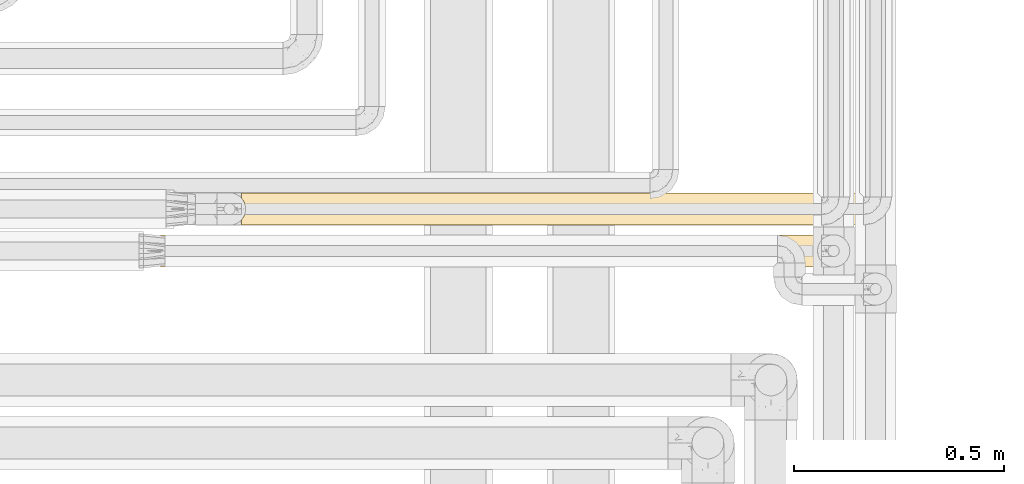
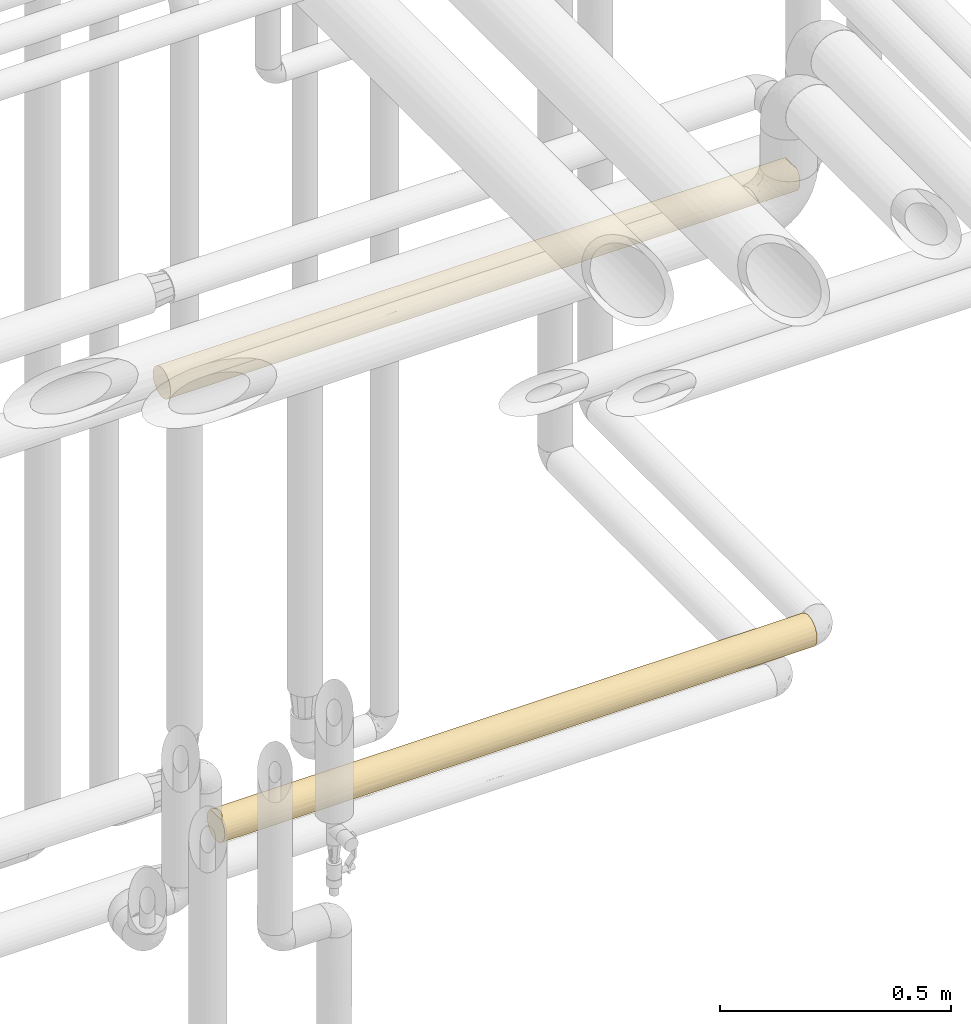
# One storey, part 49 of 827: 2 coverings.
"""IFC2X3 building model written with IfcOpenShell, lengths in millimetres."""

from ifc_helpers import new_model, entity, si_unit, converted_unit, derived_unit, direction, frame, origin, place, context, subcontext, project, spatial, faceted_brep, element, save


model = new_model("IFC2X3")

# Units and contexts
model_context = context("Model", 3, precision=0.01, world=origin(), true_north=direction((6.12303176911189e-17, 1.0)))
body_context = subcontext(model_context, "Body", "Model", "MODEL_VIEW")
ifc_project = project(units=[si_unit("LENGTHUNIT", "METRE", prefix="MILLI"), si_unit("AREAUNIT", "SQUARE_METRE"), si_unit("VOLUMEUNIT", "CUBIC_METRE"), converted_unit("PLANEANGLEUNIT", "DEGREE", entity("IfcRatioMeasure", 0.0174532925199433), si_unit("PLANEANGLEUNIT", "RADIAN"), dimensions=[0, 0, 0, 0, 0, 0, 0]), si_unit("MASSUNIT", "GRAM", prefix="KILO"), derived_unit("MASSDENSITYUNIT", [(si_unit("MASSUNIT", "GRAM", prefix="KILO"), 1), (si_unit("LENGTHUNIT", "METRE"), -3)]), derived_unit("MOMENTOFINERTIAUNIT", [(si_unit("LENGTHUNIT", "METRE"), 4)]), si_unit("TIMEUNIT", "SECOND"), si_unit("FREQUENCYUNIT", "HERTZ"), si_unit("THERMODYNAMICTEMPERATUREUNIT", "DEGREE_CELSIUS"), derived_unit("THERMALTRANSMITTANCEUNIT", [(si_unit("MASSUNIT", "GRAM", prefix="KILO"), 1), (si_unit("THERMODYNAMICTEMPERATUREUNIT", "KELVIN"), -1), (si_unit("TIMEUNIT", "SECOND"), -3)]), derived_unit("VOLUMETRICFLOWRATEUNIT", [(si_unit("LENGTHUNIT", "METRE"), 3), (si_unit("TIMEUNIT", "SECOND"), -1)]), derived_unit("MASSFLOWRATEUNIT", [(si_unit("MASSUNIT", "GRAM", prefix="KILO"), 1), (si_unit("TIMEUNIT", "SECOND"), -1)]), derived_unit("ROTATIONALFREQUENCYUNIT", [(si_unit("TIMEUNIT", "SECOND"), -1)]), si_unit("ELECTRICCURRENTUNIT", "AMPERE"), si_unit("ELECTRICVOLTAGEUNIT", "VOLT"), si_unit("POWERUNIT", "WATT"), si_unit("FORCEUNIT", "NEWTON", prefix="KILO"), si_unit("ILLUMINANCEUNIT", "LUX"), si_unit("LUMINOUSFLUXUNIT", "LUMEN"), si_unit("LUMINOUSINTENSITYUNIT", "CANDELA"), derived_unit("USERDEFINED", [(si_unit("MASSUNIT", "GRAM", prefix="KILO"), -1), (si_unit("LENGTHUNIT", "METRE"), -2), (si_unit("TIMEUNIT", "SECOND"), 3), (si_unit("LUMINOUSFLUXUNIT", "LUMEN"), 1)]), derived_unit("LINEARVELOCITYUNIT", [(si_unit("LENGTHUNIT", "METRE"), 1), (si_unit("TIMEUNIT", "SECOND"), -1)]), si_unit("PRESSUREUNIT", "PASCAL"), derived_unit("USERDEFINED", [(si_unit("LENGTHUNIT", "METRE"), -2), (si_unit("MASSUNIT", "GRAM", prefix="KILO"), 1), (si_unit("TIMEUNIT", "SECOND"), -2)]), derived_unit("LINEARFORCEUNIT", [(si_unit("MASSUNIT", "GRAM", prefix="KILO"), 1), (si_unit("LENGTHUNIT", "METRE"), 1), (si_unit("TIMEUNIT", "SECOND"), -2), (si_unit("LENGTHUNIT", "METRE"), -1)]), derived_unit("PLANARFORCEUNIT", [(si_unit("MASSUNIT", "GRAM", prefix="KILO"), 1), (si_unit("LENGTHUNIT", "METRE"), 1), (si_unit("TIMEUNIT", "SECOND"), -2), (si_unit("LENGTHUNIT", "METRE"), -2)])], contexts=[model_context])

# Site, building, storey
site_placement = place(None, origin())
site = spatial("IfcSite", under=ifc_project, at=site_placement, CompositionType="ELEMENT")
building_placement = place(site_placement, origin())
building = spatial("IfcBuilding", under=site, at=building_placement, CompositionType="ELEMENT")
storey_placement = place(building_placement, frame((0.0, 0.0, 28200.0)))
storey = spatial("IfcBuildingStorey", under=building, at=storey_placement, Name="08", CompositionType="ELEMENT", Elevation=28200.0)

# Coverings
covering_1_placement = place(storey_placement, frame((59449.82, 16339.84, 2359.94)))
element("IfcCovering", 1, at=covering_1_placement, inside=storey, Name=":ADSK_", ObjectType=":ADSK_", PredefinedType="INSULATION", context=body_context, shape_type="Brep", body=[
    faceted_brep([(1573.72, 59.2, 6.74), (1573.72, 67.15, 12.84), (1573.72, 73.25, 20.8), (1573.72, 77.09, 30.06), (1573.72, 78.4, 40.0), (1573.72, 77.51, 48.2), (1573.72, 74.9, 56.01), (1573.72, 70.68, 63.08), (1573.72, 65.05, 69.1), (1573.72, 14.94, 69.1), (1573.72, 9.31, 63.08), (1573.72, 5.09, 56.01), (1573.72, 2.48, 48.2), (1573.72, 1.6, 40.0), (1573.72, 2.9, 30.06), (1573.72, 6.74, 20.8), (1573.72, 12.84, 12.84), (1573.72, 20.8, 6.74), (1573.72, 30.06, 2.9), (1573.72, 40.0, 1.6), (1573.72, 49.93, 2.9), (0.0, 59.2, 6.74), (0.0, 49.93, 2.9), (0.0, 40.0, 1.6), (0.0, 30.06, 2.9), (0.0, 20.8, 6.74), (0.0, 12.84, 12.84), (0.0, 6.74, 20.8), (0.0, 2.9, 30.06), (0.0, 1.6, 40.0), (0.0, 2.9, 49.93), (0.0, 6.74, 59.2), (0.0, 12.84, 67.15), (0.0, 20.8, 73.25), (0.0, 30.06, 77.09), (0.0, 40.0, 78.4), (0.0, 49.93, 77.09), (0.0, 59.2, 73.25), (0.0, 67.15, 67.15), (0.0, 73.25, 59.2), (0.0, 77.09, 49.93), (0.0, 78.4, 40.0), (0.0, 77.09, 30.06), (0.0, 73.25, 20.8), (0.0, 67.15, 12.84), (324.27, 16.62, 9.53), (1091.23, 12.04, 13.67), (1270.81, 16.62, 9.53), (1318.36, 9.53, 16.62), (259.19, 9.53, 16.62), (324.56, 2.4, 32.15), (218.2, 4.8, 24.64), (468.47, 4.52, 25.3), (1359.61, 25.3, 4.52), (1230.35, 31.86, 2.47), (574.85, 2.27, 32.85), (432.75, 1.6, 40.0), (770.45, 4.55, 25.22), (1324.08, 2.42, 32.06), (1357.34, 1.6, 40.0), (1219.6, 1.6, 40.0), (1219.6, 40.0, 1.6), (1004.65, 32.06, 2.42), (561.65, 33.12, 2.22), (815.41, 27.93, 3.54), (529.72, 25.3, 4.52), (245.05, 25.3, 4.52), (324.56, 32.71, 2.29), (561.64, 11.4, 14.37), (1397.94, 4.61, 25.08), (799.23, 2.31, 32.6), (798.07, 18.26, 8.34), (864.09, 9.53, 16.62), (1101.1, 25.3, 4.52), (1072.41, 2.25, 32.94), (560.67, 17.54, 8.84), (216.37, 40.0, 1.6), (216.37, 1.6, 40.0), (1037.67, 18.17, 8.4), (1174.55, 4.52, 25.3), (972.5, 4.53, 25.27), (1056.53, 7.45, 19.61), (354.11, 40.0, 1.6), (432.75, 40.0, 1.6), (649.12, 40.0, 1.6), (708.22, 40.0, 1.6), (865.49, 40.0, 1.6), (649.12, 1.6, 40.0), (1357.34, 40.0, 1.6), (924.6, 40.0, 1.6), (1140.97, 40.0, 1.6), (1140.97, 1.6, 40.0), (924.61, 1.6, 40.0), (865.49, 1.6, 40.0), (708.23, 1.6, 40.0), (259.19, 63.37, 9.53), (324.27, 70.46, 16.62), (1168.4, 54.69, 4.52), (1249.16, 47.28, 2.29), (952.07, 47.92, 2.42), (208.32, 54.69, 4.52), (446.37, 47.16, 2.27), (219.32, 46.78, 2.2), (216.37, 78.4, 40.0), (883.57, 55.93, 5.06), (695.44, 50.43, 3.04), (1219.6, 78.4, 40.0), (1230.35, 77.52, 31.86), (1004.65, 77.57, 32.06), (1318.36, 63.37, 9.53), (1270.81, 70.46, 16.62), (556.84, 71.1, 17.47), (554.62, 65.66, 11.43), (245.05, 75.47, 25.3), (324.56, 77.7, 32.71), (529.72, 75.47, 25.3), (561.65, 77.77, 33.12), (815.41, 76.45, 27.93), (1359.61, 75.47, 25.3), (1379.06, 53.07, 3.89), (790.1, 71.59, 18.17), (850.06, 63.37, 9.53), (1101.1, 75.47, 25.3), (1084.21, 66.29, 12.01), (462.05, 54.69, 4.52), (1036.32, 71.63, 18.22), (661.94, 58.96, 6.6), (1133.78, 60.87, 7.77), (432.75, 78.4, 40.0), (649.12, 78.4, 40.0), (708.22, 78.4, 40.0), (865.49, 78.4, 40.0), (1357.34, 78.4, 40.0), (924.6, 78.4, 40.0), (1140.97, 78.4, 40.0), (1288.08, 76.41, 52.17), (1239.86, 48.24, 77.5), (1566.82, 53.36, 76.0), (1190.32, 56.68, 74.58), (1168.45, 63.21, 70.58), (1288.07, 68.03, 66.24), (1031.17, 67.73, 66.56), (206.49, 54.69, 75.47), (218.57, 46.82, 77.78), (446.71, 47.12, 77.73), (458.73, 54.69, 75.47), (654.88, 50.61, 76.9), (297.97, 63.37, 70.46), (272.32, 75.47, 54.69), (214.48, 70.46, 63.37), (473.29, 70.46, 63.37), (570.48, 76.43, 52.12), (324.56, 77.73, 47.13), (1090.13, 72.98, 59.66), (1356.65, 72.98, 59.66), (1131.67, 40.0, 78.4), (1348.04, 40.0, 78.4), (782.62, 71.69, 61.68), (621.36, 65.49, 68.71), (698.92, 40.0, 78.4), (887.25, 50.46, 76.94), (1565.02, 46.78, 77.79), (1564.42, 40.0, 78.4), (1381.25, 62.48, 71.13), (349.46, 40.0, 78.4), (1569.74, 59.51, 73.07), (958.5, 77.14, 49.74), (670.34, 58.33, 73.73), (745.92, 77.65, 47.55), (794.93, 75.41, 54.83), (864.0, 56.87, 74.49), (915.3, 40.0, 78.4), (858.12, 62.77, 70.91), (297.97, 16.62, 70.46), (324.56, 2.26, 47.13), (332.61, 31.89, 77.53), (580.28, 32.48, 77.65), (206.49, 25.3, 75.47), (570.48, 3.56, 52.12), (1075.1, 14.59, 68.79), (1259.0, 17.39, 71.03), (1190.32, 23.31, 74.58), (458.73, 25.3, 75.47), (1569.74, 20.48, 73.07), (1566.82, 26.63, 76.0), (214.48, 9.53, 63.37), (1239.86, 31.75, 77.5), (1565.02, 33.21, 77.79), (1288.07, 11.96, 66.24), (1288.08, 3.58, 52.17), (887.25, 29.53, 76.94), (690.92, 9.42, 63.23), (803.77, 5.96, 57.78), (900.85, 10.67, 64.79), (745.92, 2.35, 47.55), (958.5, 2.85, 49.74), (272.32, 4.52, 54.69), (1356.65, 7.01, 59.66), (1090.13, 7.01, 59.66), (587.9, 18.04, 71.5), (858.12, 17.22, 70.91), (869.74, 23.11, 74.48), (688.44, 25.73, 75.65), (473.29, 9.53, 63.37)], [[[0, 1, 2, 3, 4, 5, 6, 7, 8, 9, 10, 11, 12, 13, 14, 15, 16, 17, 18, 19, 20]], [[21, 22, 23, 24, 25, 26, 27, 28, 29, 30, 31, 32, 33, 34, 35, 36, 37, 38, 39, 40, 41, 42, 43, 44]], [[26, 25, 45]], [[46, 47, 48]], [[49, 26, 45]], [[50, 51, 52]], [[18, 53, 54]], [[55, 56, 50]], [[52, 57, 55]], [[58, 13, 59, 60]], [[61, 54, 62]], [[63, 64, 65]], [[25, 24, 66]], [[17, 16, 47]], [[66, 67, 65]], [[66, 45, 25]], [[49, 68, 52]], [[18, 17, 53]], [[47, 16, 48]], [[58, 69, 14]], [[70, 55, 57]], [[71, 72, 68]], [[47, 73, 53]], [[45, 66, 65]], [[60, 74, 58]], [[68, 45, 75]], [[24, 23, 76]], [[65, 67, 63]], [[77, 28, 50]], [[26, 49, 27]], [[16, 15, 48]], [[18, 54, 19]], [[46, 71, 78]], [[68, 49, 45]], [[50, 52, 55]], [[79, 74, 80]], [[51, 49, 52]], [[68, 75, 71]], [[68, 72, 57]], [[64, 71, 65]], [[46, 78, 47]], [[69, 48, 15]], [[46, 81, 72]], [[76, 67, 24]], [[67, 76, 82, 83]], [[67, 83, 63]], [[24, 67, 66]], [[64, 84, 85, 86]], [[54, 73, 62]], [[63, 84, 64]], [[64, 73, 78]], [[63, 83, 84]], [[50, 56, 77]], [[77, 29, 28]], [[51, 28, 27]], [[68, 57, 52]], [[70, 87, 55]], [[80, 72, 81]], [[72, 80, 57]], [[28, 51, 50]], [[49, 51, 27]], [[47, 53, 17]], [[54, 53, 73]], [[73, 64, 62]], [[54, 61, 88, 19]], [[64, 86, 62]], [[62, 86, 89, 90, 61]], [[81, 48, 79]], [[71, 46, 72]], [[64, 78, 71]], [[73, 47, 78]], [[48, 81, 46]], [[87, 56, 55]], [[81, 79, 80]], [[79, 58, 74]], [[80, 74, 70]], [[74, 60, 91, 92, 93]], [[74, 93, 70]], [[69, 58, 79]], [[13, 58, 14]], [[48, 69, 79]], [[14, 69, 15]], [[45, 65, 75]], [[65, 71, 75]], [[70, 57, 80]], [[70, 93, 94, 87]], [[95, 44, 96]], [[97, 98, 99]], [[98, 88, 61, 90]], [[21, 44, 95]], [[100, 22, 21]], [[101, 82, 102]], [[42, 41, 103]], [[104, 99, 105]], [[20, 88, 98]], [[106, 107, 108]], [[109, 110, 1]], [[111, 112, 96]], [[113, 114, 115]], [[104, 97, 99]], [[116, 117, 115]], [[3, 2, 118]], [[119, 20, 98]], [[43, 42, 113]], [[43, 96, 44]], [[120, 121, 112]], [[110, 122, 118]], [[3, 118, 107]], [[2, 1, 110]], [[22, 100, 102]], [[109, 123, 110]], [[113, 96, 43]], [[115, 114, 116]], [[112, 124, 95]], [[1, 0, 109]], [[3, 107, 4]], [[125, 122, 110]], [[112, 95, 96]], [[22, 102, 23]], [[100, 95, 124]], [[112, 111, 120]], [[112, 121, 126]], [[117, 120, 115]], [[125, 110, 123]], [[119, 109, 0]], [[121, 127, 104]], [[103, 114, 42]], [[96, 113, 115]], [[114, 103, 128]], [[114, 128, 116]], [[42, 114, 113]], [[117, 129, 130, 131]], [[107, 122, 108]], [[116, 129, 117]], [[117, 122, 125]], [[116, 128, 129]], [[20, 19, 88]], [[99, 98, 90]], [[98, 97, 119]], [[99, 90, 89, 86, 85]], [[85, 101, 105]], [[109, 119, 97]], [[0, 20, 119]], [[110, 118, 2]], [[107, 118, 122]], [[122, 117, 108]], [[107, 106, 132, 4]], [[117, 131, 108]], [[108, 131, 133, 134, 106]], [[127, 123, 109]], [[120, 123, 121]], [[123, 120, 125]], [[117, 125, 120]], [[95, 100, 21]], [[101, 102, 100]], [[101, 100, 124]], [[102, 82, 76, 23]], [[105, 101, 124]], [[101, 85, 84, 83, 82]], [[104, 126, 121]], [[85, 105, 99]], [[126, 105, 124]], [[121, 123, 127]], [[105, 126, 104]], [[112, 126, 124]], [[96, 115, 111]], [[115, 120, 111]], [[109, 97, 127]], [[104, 127, 97]], [[135, 132, 106, 134]], [[136, 137, 138]], [[139, 140, 141]], [[142, 143, 144]], [[145, 144, 146]], [[37, 142, 147]], [[41, 40, 103]], [[40, 39, 148]], [[39, 38, 149]], [[148, 150, 151]], [[152, 128, 103]], [[153, 140, 154]], [[140, 7, 154]], [[155, 156, 136]], [[135, 154, 6]], [[157, 150, 158]], [[159, 160, 146]], [[161, 137, 136]], [[156, 162, 161]], [[139, 163, 140]], [[164, 143, 35]], [[36, 142, 37]], [[136, 160, 155]], [[7, 140, 8]], [[163, 137, 165]], [[37, 147, 38]], [[153, 135, 166]], [[167, 158, 147]], [[168, 169, 166]], [[135, 6, 5]], [[128, 151, 168]], [[151, 150, 157]], [[141, 140, 153]], [[163, 165, 8]], [[135, 5, 132]], [[166, 135, 134]], [[161, 136, 156]], [[136, 138, 160]], [[170, 138, 139]], [[146, 167, 145]], [[147, 145, 167]], [[149, 147, 150]], [[166, 134, 133]], [[142, 144, 145]], [[166, 133, 168]], [[148, 39, 149]], [[151, 128, 152]], [[5, 4, 132]], [[152, 40, 148]], [[40, 152, 103]], [[151, 152, 148]], [[147, 149, 38]], [[148, 149, 150]], [[143, 142, 36]], [[147, 142, 145]], [[35, 143, 36]], [[143, 164, 144]], [[164, 159, 144]], [[160, 159, 171, 155]], [[159, 146, 144]], [[167, 170, 172]], [[170, 146, 160]], [[167, 172, 158]], [[172, 141, 157]], [[147, 158, 150]], [[172, 157, 158]], [[153, 166, 169]], [[157, 141, 153]], [[172, 170, 139]], [[172, 139, 141]], [[138, 137, 163]], [[140, 163, 8]], [[138, 163, 139]], [[146, 170, 167]], [[138, 170, 160]], [[6, 154, 7]], [[153, 154, 135]], [[168, 133, 131, 130, 129, 128]], [[169, 151, 157]], [[151, 169, 168]], [[153, 169, 157]], [[32, 173, 33]], [[56, 174, 77]], [[164, 175, 176]], [[177, 175, 34]], [[178, 174, 56]], [[179, 180, 181]], [[173, 182, 177]], [[183, 184, 181]], [[32, 31, 185]], [[156, 186, 187]], [[177, 34, 33]], [[9, 188, 10]], [[186, 156, 155]], [[189, 59, 12]], [[186, 190, 181]], [[191, 192, 193]], [[192, 194, 195]], [[30, 196, 31]], [[188, 197, 10]], [[198, 179, 193]], [[197, 11, 10]], [[11, 189, 12]], [[178, 194, 192]], [[195, 91, 189]], [[199, 200, 201]], [[184, 187, 186]], [[198, 189, 197]], [[176, 202, 190]], [[194, 56, 87, 94, 93, 92]], [[185, 196, 203]], [[180, 9, 183]], [[193, 179, 200]], [[195, 189, 198]], [[12, 59, 13]], [[187, 162, 156]], [[190, 155, 171, 159]], [[186, 181, 184]], [[159, 164, 176]], [[181, 190, 201]], [[185, 173, 32]], [[191, 199, 203]], [[195, 198, 192]], [[34, 175, 35]], [[194, 92, 195]], [[77, 174, 30]], [[203, 196, 178]], [[30, 29, 77]], [[189, 91, 60, 59]], [[178, 196, 174]], [[30, 174, 196]], [[196, 185, 31]], [[173, 185, 203]], [[173, 177, 33]], [[175, 177, 182]], [[175, 182, 176]], [[175, 164, 35]], [[202, 176, 182]], [[190, 159, 176]], [[199, 202, 182]], [[201, 190, 202]], [[182, 173, 199]], [[203, 199, 173]], [[193, 192, 198]], [[178, 192, 191]], [[179, 198, 188]], [[200, 199, 191]], [[180, 179, 188]], [[201, 179, 181]], [[9, 180, 188]], [[183, 181, 180]], [[199, 201, 202]], [[201, 200, 179]], [[191, 193, 200]], [[178, 191, 203]], [[198, 197, 188]], [[11, 197, 189]], [[155, 190, 186]], [[56, 194, 178]], [[92, 91, 195]], [[187, 184, 183, 9, 8, 165, 137, 161, 162]]]),
])
covering_2_placement = place(storey_placement, frame((59641.37, 16439.66, 1060.0)))
element("IfcCovering", 2, at=covering_2_placement, inside=storey, Name=":ADSK_", ObjectType=":ADSK_", PredefinedType="INSULATION", context=body_context, shape_type="Brep", body=[
    faceted_brep([(1482.17, 56.01, 5.09), (1482.17, 63.08, 9.31), (1482.17, 69.1, 14.94), (1482.17, 69.1, 65.05), (1482.17, 63.08, 70.68), (1482.17, 56.01, 74.9), (1482.17, 48.2, 77.51), (1482.17, 40.0, 78.4), (1482.17, 30.06, 77.09), (1482.17, 20.8, 73.25), (1482.17, 12.84, 67.15), (1482.17, 6.74, 59.2), (1482.17, 2.9, 49.93), (1482.17, 1.6, 40.0), (1482.17, 2.9, 30.06), (1482.17, 6.74, 20.8), (1482.17, 12.84, 12.84), (1482.17, 20.8, 6.74), (1482.17, 30.06, 2.9), (1482.17, 40.0, 1.6), (1482.17, 48.2, 2.48), (1.6, 77.09, 30.06), (1.6, 73.25, 20.8), (1.6, 67.15, 12.84), (1.6, 59.2, 6.74), (1.6, 49.93, 2.9), (1.6, 40.0, 1.6), (1.6, 30.06, 2.9), (1.6, 20.8, 6.74), (1.6, 12.84, 12.84), (1.6, 6.74, 20.8), (1.6, 2.9, 30.06), (1.6, 1.6, 40.0), (1.6, 2.48, 48.2), (1.6, 5.09, 56.01), (1.6, 9.31, 63.08), (1.6, 14.94, 69.1), (1.6, 65.05, 69.1), (1.6, 70.68, 63.08), (1.6, 74.9, 56.01), (1.6, 77.51, 48.2), (1.6, 78.4, 40.0), (260.79, 9.53, 16.62), (1079.82, 4.52, 25.3), (996.78, 9.74, 16.35), (1228.27, 9.53, 16.62), (618.06, 2.4, 32.16), (434.34, 1.6, 40.0), (326.15, 2.3, 32.67), (325.87, 16.62, 9.53), (972.98, 32.78, 2.28), (1226.22, 31.12, 2.63), (1038.18, 25.3, 4.52), (196.99, 3.95, 26.75), (411.91, 4.52, 25.3), (217.97, 1.6, 40.0), (1174.63, 1.6, 40.0), (1259.87, 3.03, 29.6), (784.75, 28.08, 3.49), (563.24, 33.12, 2.22), (531.31, 25.3, 4.52), (246.65, 25.3, 4.52), (1189.29, 16.62, 9.53), (326.15, 32.71, 2.29), (1266.07, 23.58, 5.28), (1277.15, 5.7, 22.72), (1061.14, 2.24, 33.0), (867.21, 17.07, 9.19), (667.72, 5.19, 23.76), (882.41, 5.95, 22.23), (856.74, 3.13, 29.26), (217.97, 40.0, 1.6), (567.96, 17.91, 8.58), (513.04, 11.66, 14.08), (867.09, 1.6, 40.0), (765.28, 9.53, 16.62), (309.14, 40.0, 1.6), (434.34, 40.0, 1.6), (650.71, 40.0, 1.6), (833.05, 40.0, 1.6), (867.09, 40.0, 1.6), (616.68, 40.0, 1.6), (650.71, 1.6, 40.0), (1049.43, 40.0, 1.6), (1174.63, 40.0, 1.6), (1265.8, 40.0, 1.6), (1196.53, 52.17, 3.58), (1148.31, 77.5, 31.75), (1475.27, 76.0, 26.63), (1098.77, 74.58, 23.31), (1076.91, 70.58, 16.78), (1196.52, 66.24, 11.96), (939.63, 66.56, 12.26), (300.81, 77.55, 31.97), (417.36, 75.47, 25.3), (184.25, 75.47, 25.3), (795.7, 76.94, 29.53), (539.8, 77.57, 32.1), (607.38, 78.4, 40.0), (445.59, 54.69, 4.52), (199.96, 54.69, 4.52), (294.48, 63.37, 9.53), (322.77, 48.07, 2.45), (557.97, 47.85, 2.41), (636.88, 63.22, 9.41), (998.59, 59.66, 7.01), (1265.11, 59.66, 7.01), (1040.12, 78.4, 40.0), (1256.5, 78.4, 40.0), (877.71, 74.37, 22.88), (642.56, 74.5, 23.14), (1473.48, 77.79, 33.21), (1472.87, 78.4, 40.0), (1289.71, 71.13, 17.51), (304.49, 78.4, 40.0), (1478.2, 73.07, 20.48), (255.5, 70.46, 16.62), (866.95, 49.74, 2.85), (511.42, 70.5, 16.67), (681.05, 54.5, 4.44), (766.58, 70.91, 17.22), (823.75, 78.4, 40.0), (583.15, 77.6, 47.77), (398.08, 76.41, 52.17), (795.7, 76.94, 50.46), (1148.31, 77.5, 48.24), (290.05, 73.02, 59.58), (182.01, 76.41, 52.17), (293.77, 59.37, 73.15), (5.57, 59.51, 73.07), (385.89, 68.03, 66.24), (671.75, 64.51, 69.55), (8.5, 53.36, 76.0), (1208.58, 66.24, 68.03), (10.29, 46.78, 77.79), (227.27, 40.0, 78.4), (317.17, 50.2, 77.01), (546.77, 73.45, 58.85), (1085.36, 70.55, 63.25), (1294.06, 71.13, 62.47), (1098.77, 74.58, 56.68), (1475.27, 76.0, 53.36), (1473.48, 77.79, 46.78), (443.64, 40.0, 78.4), (660.02, 40.0, 78.4), (569.25, 48.32, 77.48), (1208.59, 52.17, 76.41), (1265.8, 40.0, 78.4), (569.18, 56.76, 74.54), (1028.49, 59.66, 72.98), (1270.91, 59.66, 72.98), (795.01, 58.79, 73.48), (946.33, 66.53, 67.75), (1478.2, 73.07, 59.51), (1071.09, 40.0, 78.4), (1179.28, 40.0, 78.4), (900.38, 50.64, 76.89), (766.58, 70.91, 62.77), (877.71, 74.37, 57.11), (876.39, 40.0, 78.4), (10.9, 40.0, 78.4), (335.45, 31.75, 77.5), (688.07, 29.53, 76.94), (406.86, 16.78, 70.58), (194.06, 17.51, 71.13), (287.24, 11.96, 66.24), (218.66, 7.01, 59.66), (1228.27, 16.62, 70.46), (1189.29, 9.53, 63.37), (5.57, 20.48, 73.07), (8.5, 26.63, 76.0), (10.29, 33.21, 77.79), (485.18, 7.01, 59.66), (287.23, 3.58, 52.17), (1182.96, 31.97, 77.55), (1283.8, 4.52, 54.69), (1066.4, 25.3, 75.47), (972.35, 16.67, 70.5), (384.99, 23.31, 74.58), (1160.99, 2.45, 48.07), (1299.52, 25.3, 75.47), (544.14, 12.26, 66.56), (802.71, 4.44, 54.5), (616.82, 2.85, 49.74), (925.8, 2.41, 47.85), (606.06, 22.88, 74.37), (841.2, 23.14, 74.5), (1038.18, 4.52, 54.69), (943.97, 32.1, 77.57), (846.89, 9.41, 63.22), (717.19, 17.22, 70.91)], [[[0, 1, 2, 3, 4, 5, 6, 7, 8, 9, 10, 11, 12, 13, 14, 15, 16, 17, 18, 19, 20]], [[21, 22, 23, 24, 25, 26, 27, 28, 29, 30, 31, 32, 33, 34, 35, 36, 37, 38, 39, 40, 41]], [[29, 42, 30]], [[43, 44, 45]], [[46, 47, 48]], [[42, 29, 49]], [[50, 51, 52]], [[53, 54, 48]], [[31, 48, 55]], [[13, 56, 57]], [[58, 50, 52]], [[59, 58, 60]], [[28, 27, 61]], [[17, 16, 62]], [[61, 63, 60]], [[61, 49, 28]], [[28, 49, 29]], [[64, 52, 51]], [[62, 16, 45]], [[57, 65, 14]], [[66, 57, 56]], [[52, 62, 67]], [[62, 52, 64]], [[68, 69, 70]], [[70, 46, 68]], [[27, 26, 71]], [[49, 72, 73]], [[31, 53, 48]], [[60, 63, 59]], [[73, 54, 42]], [[16, 15, 45]], [[18, 51, 19]], [[45, 44, 62]], [[73, 42, 49]], [[66, 74, 70]], [[53, 42, 54]], [[43, 65, 57]], [[43, 69, 44]], [[71, 63, 27]], [[49, 61, 60]], [[75, 73, 72]], [[67, 72, 58]], [[63, 71, 76, 77]], [[63, 77, 59]], [[27, 63, 61]], [[58, 78, 79, 80]], [[80, 50, 58]], [[59, 78, 58]], [[67, 58, 52]], [[49, 60, 72]], [[73, 75, 68]], [[58, 72, 60]], [[75, 72, 67]], [[59, 77, 81, 78]], [[55, 48, 47]], [[55, 32, 31]], [[46, 48, 54]], [[46, 54, 68]], [[46, 74, 82, 47]], [[31, 30, 53]], [[42, 53, 30]], [[73, 68, 54]], [[70, 69, 43]], [[66, 70, 43]], [[74, 46, 70]], [[57, 66, 43]], [[74, 66, 56]], [[43, 45, 65]], [[57, 14, 13]], [[45, 15, 65]], [[14, 65, 15]], [[50, 80, 83, 84]], [[51, 84, 85, 19]], [[84, 51, 50]], [[64, 18, 17]], [[18, 64, 51]], [[62, 64, 17]], [[68, 75, 69]], [[69, 75, 44]], [[75, 67, 44]], [[62, 44, 67]], [[86, 85, 84, 83]], [[87, 88, 89]], [[90, 91, 92]], [[93, 94, 95]], [[96, 97, 98]], [[99, 100, 101]], [[24, 100, 25]], [[76, 102, 103]], [[101, 104, 99]], [[92, 91, 105]], [[25, 100, 102]], [[105, 91, 106]], [[91, 1, 106]], [[107, 108, 87]], [[86, 106, 0]], [[24, 23, 101]], [[96, 109, 110]], [[111, 88, 87]], [[108, 112, 111]], [[90, 113, 91]], [[114, 93, 41]], [[21, 95, 22]], [[87, 96, 107]], [[1, 91, 2]], [[113, 88, 115]], [[23, 116, 101]], [[105, 86, 117]], [[116, 94, 118]], [[119, 117, 103]], [[86, 0, 20]], [[113, 115, 2]], [[86, 20, 85]], [[117, 86, 83]], [[111, 87, 108]], [[87, 89, 96]], [[109, 96, 89]], [[93, 97, 94]], [[23, 22, 116]], [[25, 102, 26]], [[116, 118, 101]], [[103, 79, 78, 81, 77, 76]], [[114, 97, 93]], [[92, 104, 120]], [[119, 105, 117]], [[20, 19, 85]], [[95, 116, 22]], [[94, 110, 118]], [[101, 100, 24]], [[102, 100, 99]], [[102, 99, 103]], [[102, 76, 71, 26]], [[119, 103, 99]], [[103, 117, 79]], [[99, 104, 119]], [[105, 119, 104]], [[104, 92, 105]], [[120, 109, 90]], [[120, 90, 92]], [[89, 88, 113]], [[91, 113, 2]], [[89, 113, 90]], [[21, 41, 93]], [[116, 95, 94]], [[21, 93, 95]], [[97, 114, 98]], [[121, 107, 96, 98]], [[110, 97, 96]], [[0, 106, 1]], [[105, 106, 86]], [[90, 109, 89]], [[110, 109, 120]], [[110, 120, 118]], [[110, 94, 97]], [[120, 104, 118]], [[101, 118, 104]], [[117, 83, 80, 79]], [[122, 114, 123]], [[107, 124, 125]], [[126, 123, 127]], [[128, 37, 129]], [[130, 128, 131]], [[129, 132, 128]], [[4, 3, 133]], [[39, 127, 40]], [[134, 135, 136]], [[123, 126, 137]], [[138, 139, 140]], [[134, 136, 132]], [[140, 139, 141]], [[125, 124, 140]], [[108, 125, 142]], [[143, 144, 145]], [[128, 132, 136]], [[130, 38, 37]], [[146, 6, 5]], [[114, 40, 127]], [[6, 147, 7]], [[128, 136, 148]], [[136, 145, 148]], [[149, 150, 133]], [[151, 152, 131]], [[150, 5, 4]], [[114, 122, 121, 98]], [[141, 142, 125]], [[139, 3, 153]], [[146, 154, 155, 147]], [[38, 130, 126]], [[108, 107, 125]], [[137, 124, 122]], [[133, 152, 149]], [[5, 150, 146]], [[154, 146, 156]], [[138, 157, 152]], [[146, 149, 156]], [[147, 6, 146]], [[142, 112, 108]], [[124, 107, 121]], [[125, 140, 141]], [[124, 121, 122]], [[158, 140, 124]], [[151, 156, 149]], [[41, 40, 114]], [[156, 144, 159, 154]], [[133, 150, 4]], [[146, 150, 149]], [[39, 38, 126]], [[114, 127, 123]], [[126, 127, 39]], [[137, 130, 157]], [[130, 137, 126]], [[137, 157, 158]], [[131, 128, 148]], [[37, 128, 130]], [[145, 156, 148]], [[138, 152, 133]], [[131, 152, 157]], [[130, 131, 157]], [[151, 131, 148]], [[133, 3, 139]], [[138, 140, 158]], [[139, 153, 141]], [[133, 139, 138]], [[156, 151, 148]], [[152, 151, 149]], [[143, 145, 136]], [[156, 145, 144]], [[135, 134, 160]], [[135, 143, 136]], [[137, 122, 123]], [[137, 158, 124]], [[138, 158, 157]], [[143, 161, 162]], [[163, 164, 165]], [[35, 166, 165]], [[10, 167, 168]], [[35, 165, 36]], [[169, 164, 170]], [[171, 170, 161]], [[143, 135, 161]], [[172, 165, 166]], [[173, 166, 34]], [[174, 7, 147, 155]], [[11, 175, 12]], [[176, 177, 167]], [[161, 170, 178]], [[12, 175, 179]], [[174, 176, 180]], [[181, 165, 172]], [[11, 10, 168]], [[182, 183, 184]], [[56, 179, 184]], [[173, 34, 33]], [[8, 180, 9]], [[162, 185, 186]], [[163, 165, 181]], [[47, 173, 55]], [[172, 173, 183]], [[135, 160, 171]], [[187, 175, 168]], [[162, 188, 159]], [[168, 189, 187]], [[164, 169, 36]], [[173, 33, 55]], [[183, 173, 47]], [[171, 161, 135]], [[161, 178, 162]], [[185, 162, 178]], [[174, 188, 176]], [[10, 9, 167]], [[12, 179, 13]], [[167, 177, 168]], [[184, 82, 74, 56]], [[155, 188, 174]], [[181, 189, 190]], [[182, 172, 183]], [[33, 32, 55]], [[180, 167, 9]], [[176, 186, 177]], [[168, 175, 11]], [[179, 175, 187]], [[179, 187, 184]], [[179, 56, 13]], [[182, 184, 187]], [[184, 183, 82]], [[187, 189, 182]], [[172, 182, 189]], [[189, 181, 172]], [[190, 185, 163]], [[190, 163, 181]], [[178, 170, 164]], [[165, 164, 36]], [[178, 164, 163]], [[8, 7, 174]], [[167, 180, 176]], [[8, 174, 180]], [[188, 155, 154, 159]], [[144, 143, 162, 159]], [[186, 188, 162]], [[34, 166, 35]], [[172, 166, 173]], [[163, 185, 178]], [[186, 185, 190]], [[186, 190, 177]], [[186, 176, 188]], [[190, 189, 177]], [[168, 177, 189]], [[183, 47, 82]], [[142, 141, 153, 3, 2, 115, 88, 111, 112]], [[36, 169, 170, 171, 160, 134, 132, 129, 37]]]),
])

save(model, "model.ifc")
